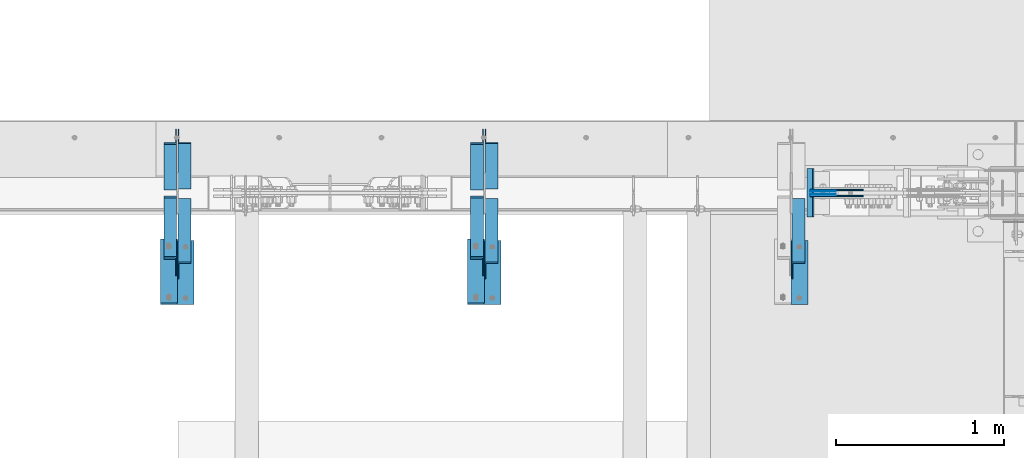
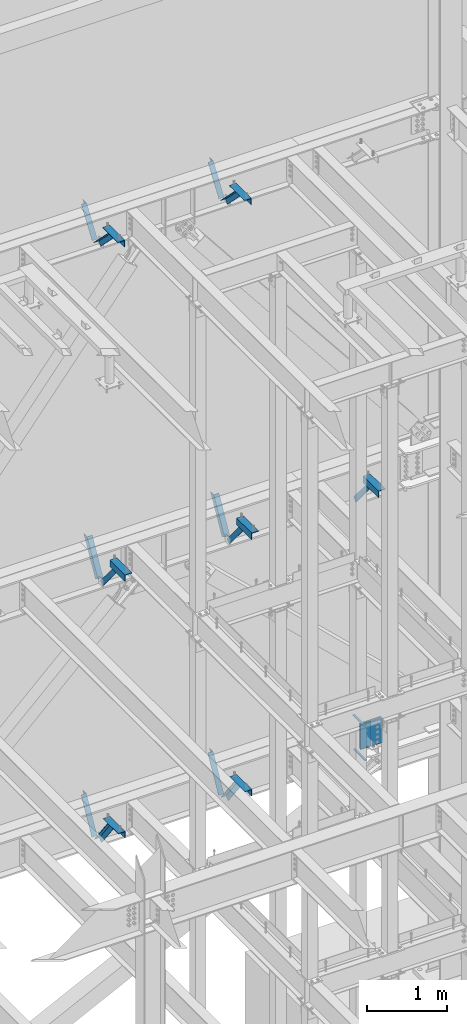
# One storey, part 925 of 1179: 13 beams, 13 members, 23 elements without a shape of their own.
"""IFC2X3 building model written with IfcOpenShell, lengths in millimetres."""

from ifc_helpers import new_model, si_unit, frame, origin_with_axes, place, context, subcontext, project, spatial, faceted_brep, material, type_object, element, aggregate, save


model = new_model("IFC2X3")

# Units and contexts
model_context = context("Model", 3, precision=1e-05, world=origin_with_axes())
body_context = subcontext(model_context, "Body", "Model", "MODEL_VIEW")
ifc_project = project(units=[si_unit("LENGTHUNIT", "METRE", prefix="MILLI"), si_unit("AREAUNIT", "SQUARE_METRE"), si_unit("VOLUMEUNIT", "CUBIC_METRE"), si_unit("MASSUNIT", "GRAM", prefix="KILO"), si_unit("TIMEUNIT", "SECOND"), si_unit("PLANEANGLEUNIT", "RADIAN"), si_unit("SOLIDANGLEUNIT", "STERADIAN"), si_unit("THERMODYNAMICTEMPERATUREUNIT", "DEGREE_CELSIUS"), si_unit("LUMINOUSINTENSITYUNIT", "LUMEN")], contexts=[model_context])

# Site, building, storey
site_placement = place(None, origin_with_axes())
site = spatial("IfcSite", under=ifc_project, at=site_placement, CompositionType="ELEMENT")
building_placement = place(site_placement, origin_with_axes())
building = spatial("IfcBuilding", under=site, at=building_placement, Name="Undefined", CompositionType="ELEMENT")
storey_placement = place(building_placement, origin_with_axes())
storey = spatial("IfcBuildingStorey", under=building, at=storey_placement, Name="Undefined", CompositionType="ELEMENT", Elevation=0.0)

# Assembly, member
assembly_1_placement = place(storey_placement, origin_with_axes())
assembly_1 = element("IfcElementAssembly", 1, at=assembly_1_placement, inside=storey, Name="ANGLE", AssemblyPlace="NOTDEFINED", PredefinedType="RIGID_FRAME")
ifc_material_1 = material(Name="STEEL/A36")
member_type = type_object("IfcMemberType", Name="L3X3X1/4", PredefinedType="NOTDEFINED")
member_1_placement = place(assembly_1_placement, frame((11503.025, 41137.0679040265, 7518.83524528677), z_axis=(0.0, -0.767806695844832, -0.640681572870519), x_axis=(0.0, -0.640681572870519, 0.767806695844831)))
member_1 = element("IfcMember", 2, at=member_1_placement, type_object=member_type, material=ifc_material_1, Name="ANGLE", ObjectType="L3X3X1/4", context=body_context, shape_type="Brep", body=[
    faceted_brep([(0.0, 38.0999999999985, -38.0999999999999), (0.0, 38.0999999999985, 38.0999999999999), (655.633410548446, 38.1000000000004, 38.0999999994965), (592.049781860664, 38.1000000000004, -38.1000000005733), (0.0, 31.75, 38.1000000000004), (655.633410548446, 31.75, 38.0999999994965), (0.0, 31.75, -31.75), (597.348417584646, 31.75, -31.7500000005675), (0.0, -38.0999999999985, -31.75), (597.348417584646, -38.1000000000004, -31.7500000005675), (0.0, -38.0999999999985, -38.0999999999999), (592.049781860664, -38.1000000000004, -38.1000000005733)], [[[0, 1, 2, 3]], [[1, 4, 5, 2]], [[4, 6, 7, 5]], [[6, 8, 9, 7]], [[8, 10, 11, 9]], [[10, 0, 3, 11]], [[5, 7, 9, 11, 3, 2]], [[10, 8, 6, 4, 1, 0]]]),
])
aggregate(assembly_1, [member_1])

assembly_2_placement = place(storey_placement, origin_with_axes())
assembly_2 = element("IfcElementAssembly", 3, at=assembly_2_placement, inside=storey, Name="ANGLE", AssemblyPlace="NOTDEFINED", PredefinedType="RIGID_FRAME")
member_2_placement = place(assembly_2_placement, frame((15160.625, 41137.0679040265, 7518.83524528677), z_axis=(0.0, -0.767806695844832, -0.640681572870519), x_axis=(0.0, -0.640681572870519, 0.767806695844831)))
member_2 = element("IfcMember", 4, at=member_2_placement, type_object=member_type, material=ifc_material_1, Name="ANGLE", ObjectType="L3X3X1/4", context=body_context, shape_type="Brep", body=[
    faceted_brep([(0.0, 38.0999999999985, -38.0999999999999), (0.0, 38.0999999999985, 38.0999999999999), (655.633410548446, 38.1000000000004, 38.0999999994965), (592.049781860664, 38.1000000000004, -38.1000000005733), (0.0, 31.75, 38.1000000000004), (655.633410548446, 31.75, 38.0999999994965), (0.0, 31.75, -31.75), (597.348417584646, 31.75, -31.7500000005675), (0.0, -38.0999999999985, -31.75), (597.348417584646, -38.1000000000004, -31.7500000005675), (0.0, -38.0999999999985, -38.0999999999999), (592.049781860664, -38.1000000000004, -38.1000000005733)], [[[0, 1, 2, 3]], [[1, 4, 5, 2]], [[4, 6, 7, 5]], [[6, 8, 9, 7]], [[8, 10, 11, 9]], [[10, 0, 3, 11]], [[5, 7, 9, 11, 3, 2]], [[10, 8, 6, 4, 1, 0]]]),
])
aggregate(assembly_2, [member_2])

assembly_3_placement = place(storey_placement, origin_with_axes())
assembly_3 = element("IfcElementAssembly", 5, at=assembly_3_placement, inside=storey, Name="ANGLE", AssemblyPlace="NOTDEFINED", PredefinedType="RIGID_FRAME")
member_3_placement = place(assembly_3_placement, frame((13331.825, 41137.0679040265, 7518.83524528677), z_axis=(0.0, -0.767806695844832, -0.640681572870519), x_axis=(0.0, -0.640681572870519, 0.767806695844831)))
member_3 = element("IfcMember", 6, at=member_3_placement, type_object=member_type, material=ifc_material_1, Name="ANGLE", ObjectType="L3X3X1/4", context=body_context, shape_type="Brep", body=[
    faceted_brep([(0.0, 38.0999999999985, -38.0999999999999), (0.0, 38.0999999999985, 38.0999999999999), (655.633410548446, 38.1000000000004, 38.0999999994965), (592.049781860664, 38.1000000000004, -38.1000000005733), (0.0, 31.75, 38.1000000000004), (655.633410548446, 31.75, 38.0999999994965), (0.0, 31.75, -31.75), (597.348417584646, 31.75, -31.7500000005675), (0.0, -38.0999999999985, -31.75), (597.348417584646, -38.1000000000004, -31.7500000005675), (0.0, -38.0999999999985, -38.0999999999999), (592.049781860664, -38.1000000000004, -38.1000000005733)], [[[0, 1, 2, 3]], [[1, 4, 5, 2]], [[4, 6, 7, 5]], [[6, 8, 9, 7]], [[8, 10, 11, 9]], [[10, 0, 3, 11]], [[5, 7, 9, 11, 3, 2]], [[10, 8, 6, 4, 1, 0]]]),
])
aggregate(assembly_3, [member_3])

assembly_4_placement = place(storey_placement, origin_with_axes())
assembly_4 = element("IfcElementAssembly", 7, at=assembly_4_placement, inside=storey, Name="ANGLE", AssemblyPlace="NOTDEFINED", PredefinedType="RIGID_FRAME")
member_4_placement = place(assembly_4_placement, frame((13331.825, 41656.0, 8227.31342088179), z_axis=(0.0, 0.872675718014636, -0.488300206008189), x_axis=(0.0, -0.48830020600819, -0.872675718014636)))
member_4 = element("IfcMember", 8, at=member_4_placement, type_object=member_type, material=ifc_material_1, Name="ANGLE", ObjectType="L3X3X1/4", context=body_context, shape_type="Brep", body=[
    faceted_brep([(266.09845322503, 38.1000000000004, -38.1000000001477), (223.461222774196, 38.1000000000004, 38.0999999997293), (818.212094408347, 38.1000000000004, 38.0999999992346), (818.21209440822, 38.1000000000004, -38.100000000617), (223.461222774196, 31.75, 38.0999999997293), (818.212094408347, 31.75, 38.0999999992346), (262.545350687458, 31.75, -31.7500000001601), (818.212094408227, 31.75, -31.7500000006257), (262.545350687458, -38.1000000000004, -31.7500000001601), (818.212094408227, -38.1000000000004, -31.7500000006257), (266.09845322503, -38.1000000000004, -38.1000000001477), (818.21209440822, -38.1000000000004, -38.100000000617)], [[[0, 1, 2, 3]], [[1, 4, 5, 2]], [[4, 6, 7, 5]], [[6, 8, 9, 7]], [[8, 10, 11, 9]], [[10, 0, 3, 11]], [[5, 7, 9, 11, 3, 2]], [[10, 8, 6, 4, 1, 0]]]),
])
aggregate(assembly_4, [member_4])

assembly_5_placement = place(storey_placement, origin_with_axes())
assembly_5 = element("IfcElementAssembly", 9, at=assembly_5_placement, inside=storey, Name="ANGLE", AssemblyPlace="NOTDEFINED", PredefinedType="RIGID_FRAME")
member_5_placement = place(assembly_5_placement, frame((11503.025, 41656.0, 8227.31342088179), z_axis=(0.0, 0.872675718014636, -0.488300206008189), x_axis=(0.0, -0.48830020600819, -0.872675718014636)))
member_5 = element("IfcMember", 10, at=member_5_placement, type_object=member_type, material=ifc_material_1, Name="ANGLE", ObjectType="L3X3X1/4", context=body_context, shape_type="Brep", body=[
    faceted_brep([(266.09845322503, 38.1000000000004, -38.1000000001477), (223.461222774196, 38.1000000000004, 38.0999999997293), (818.212094408347, 38.1000000000004, 38.0999999992346), (818.21209440822, 38.1000000000004, -38.100000000617), (223.461222774196, 31.75, 38.0999999997293), (818.212094408347, 31.75, 38.0999999992346), (262.545350687458, 31.75, -31.7500000001601), (818.212094408227, 31.75, -31.7500000006257), (262.545350687458, -38.1000000000004, -31.7500000001601), (818.212094408227, -38.1000000000004, -31.7500000006257), (266.09845322503, -38.1000000000004, -38.1000000001477), (818.21209440822, -38.1000000000004, -38.100000000617)], [[[0, 1, 2, 3]], [[1, 4, 5, 2]], [[4, 6, 7, 5]], [[6, 8, 9, 7]], [[8, 10, 11, 9]], [[10, 0, 3, 11]], [[5, 7, 9, 11, 3, 2]], [[10, 8, 6, 4, 1, 0]]]),
])
aggregate(assembly_5, [member_5])

assembly_6_placement = place(storey_placement, origin_with_axes())
assembly_6 = element("IfcElementAssembly", 11, at=assembly_6_placement, inside=storey, Name="ANGLE", AssemblyPlace="NOTDEFINED", PredefinedType="RIGID_FRAME")
member_6_placement = place(assembly_6_placement, frame((13246.10025, 41256.8364339201, 3601.33927004389), z_axis=(0.0, 0.873306509536275, -0.487171161299155), x_axis=(0.0, 0.487171161299156, 0.873306509536275)))
member_6 = element("IfcMember", 12, at=member_6_placement, type_object=member_type, material=ifc_material_1, Name="ANGLE", ObjectType="L3X3X1/4", context=body_context, shape_type="Brep", body=[
    faceted_brep([(0.0, 38.0999999999985, -38.0999999999999), (0.0, 38.0999999999985, 38.0999999999999), (594.661720177039, 38.1000000000004, 38.1000000011991), (552.153801037723, 38.1000000000004, -38.0999999989144), (0.0, 31.75, 38.1000000000004), (594.661720177039, 31.75, 38.1000000011991), (0.0, 31.75, -31.75), (555.696127632669, 31.75, -31.7499999988941), (0.0, -38.0999999999985, -31.75), (555.696127632669, -38.1000000000004, -31.7499999988941), (0.0, -38.0999999999985, -38.0999999999999), (552.153801037723, -38.1000000000004, -38.0999999989144)], [[[0, 1, 2, 3]], [[1, 4, 5, 2]], [[4, 6, 7, 5]], [[6, 8, 9, 7]], [[8, 10, 11, 9]], [[10, 0, 3, 11]], [[5, 7, 9, 11, 3, 2]], [[10, 8, 6, 4, 1, 0]]]),
])
aggregate(assembly_6, [member_6])

assembly_7_placement = place(storey_placement, origin_with_axes())
assembly_7 = element("IfcElementAssembly", 13, at=assembly_7_placement, inside=storey, Name="ANGLE", AssemblyPlace="NOTDEFINED", PredefinedType="RIGID_FRAME")
member_7_placement = place(assembly_7_placement, frame((13246.10025, 40722.5021746856, 4156.39103856133), z_axis=(0.0, -0.797785167426298, -0.602941810322185), x_axis=(0.0, 0.602941810322187, -0.797785167426297)))
member_7 = element("IfcMember", 14, at=member_7_placement, type_object=member_type, material=ifc_material_1, Name="ANGLE", ObjectType="L3X3X1/4", context=body_context, shape_type="Brep", body=[
    faceted_brep([(110.776215380578, 38.1000000000004, -38.1000000000058), (53.1865686658894, 38.1000000000004, 38.1000000001659), (690.351875241478, 38.1000000000004, 38.1000000007261), (690.351875241598, 38.1000000000004, -38.0999999994892), (53.1865686658894, 31.75, 38.1000000001659), (690.351875241478, 31.75, 38.1000000007261), (105.977078154352, 31.75, -31.7499999999927), (690.351875241595, 31.75, -31.7499999994689), (105.977078154352, -38.1000000000004, -31.7499999999927), (690.351875241595, -38.1000000000004, -31.7499999994689), (110.776215380578, -38.1000000000004, -38.1000000000058), (690.351875241598, -38.1000000000004, -38.0999999994892)], [[[0, 1, 2, 3]], [[1, 4, 5, 2]], [[4, 6, 7, 5]], [[6, 8, 9, 7]], [[8, 10, 11, 9]], [[10, 0, 3, 11]], [[5, 7, 9, 11, 3, 2]], [[10, 8, 6, 4, 1, 0]]]),
])
aggregate(assembly_7, [member_7])

assembly_8_placement = place(storey_placement, origin_with_axes())
assembly_8 = element("IfcElementAssembly", 15, at=assembly_8_placement, inside=storey, Name="ANGLE", AssemblyPlace="NOTDEFINED", PredefinedType="RIGID_FRAME")
member_8_placement = place(assembly_8_placement, frame((11417.30025, 40722.5021746856, 4156.39103856133), z_axis=(0.0, -0.797785167426298, -0.602941810322185), x_axis=(0.0, 0.602941810322187, -0.797785167426297)))
member_8 = element("IfcMember", 16, at=member_8_placement, type_object=member_type, material=ifc_material_1, Name="ANGLE", ObjectType="L3X3X1/4", context=body_context, shape_type="Brep", body=[
    faceted_brep([(110.776215380578, 38.1000000000004, -38.1000000000058), (53.1865686658894, 38.1000000000004, 38.1000000001659), (690.351875241478, 38.1000000000004, 38.1000000007261), (690.351875241598, 38.1000000000004, -38.0999999994892), (53.1865686658894, 31.75, 38.1000000001659), (690.351875241478, 31.75, 38.1000000007261), (105.977078154352, 31.75, -31.7499999999927), (690.351875241595, 31.75, -31.7499999994689), (105.977078154352, -38.1000000000004, -31.7499999999927), (690.351875241595, -38.1000000000004, -31.7499999994689), (110.776215380578, -38.1000000000004, -38.1000000000058), (690.351875241598, -38.1000000000004, -38.0999999994892)], [[[0, 1, 2, 3]], [[1, 4, 5, 2]], [[4, 6, 7, 5]], [[6, 8, 9, 7]], [[8, 10, 11, 9]], [[10, 0, 3, 11]], [[5, 7, 9, 11, 3, 2]], [[10, 8, 6, 4, 1, 0]]]),
])
aggregate(assembly_8, [member_8])

assembly_9_placement = place(storey_placement, origin_with_axes())
assembly_9 = element("IfcElementAssembly", 17, at=assembly_9_placement, inside=storey, Name="ANGLE", AssemblyPlace="NOTDEFINED", PredefinedType="RIGID_FRAME")
member_9_placement = place(assembly_9_placement, frame((11417.30025, 41256.8364339201, 3601.33927004389), z_axis=(0.0, 0.873306509536275, -0.487171161299155), x_axis=(0.0, 0.487171161299156, 0.873306509536275)))
member_9 = element("IfcMember", 18, at=member_9_placement, type_object=member_type, material=ifc_material_1, Name="ANGLE", ObjectType="L3X3X1/4", context=body_context, shape_type="Brep", body=[
    faceted_brep([(0.0, 38.0999999999985, -38.0999999999999), (0.0, 38.0999999999985, 38.0999999999999), (594.661720177039, 38.1000000000004, 38.1000000011991), (552.153801037723, 38.1000000000004, -38.0999999989144), (0.0, 31.75, 38.1000000000004), (594.661720177039, 31.75, 38.1000000011991), (0.0, 31.75, -31.75), (555.696127632669, 31.75, -31.7499999988941), (0.0, -38.0999999999985, -31.75), (555.696127632669, -38.1000000000004, -31.7499999988941), (0.0, -38.0999999999985, -38.0999999999999), (552.153801037723, -38.1000000000004, -38.0999999989144)], [[[0, 1, 2, 3]], [[1, 4, 5, 2]], [[4, 6, 7, 5]], [[6, 8, 9, 7]], [[8, 10, 11, 9]], [[10, 0, 3, 11]], [[5, 7, 9, 11, 3, 2]], [[10, 8, 6, 4, 1, 0]]]),
])
aggregate(assembly_9, [member_9])

assembly_10_placement = place(storey_placement, origin_with_axes())
assembly_10 = element("IfcElementAssembly", 19, at=assembly_10_placement, inside=storey, Name="ANGLE", AssemblyPlace="NOTDEFINED", PredefinedType="RIGID_FRAME")
member_10_placement = place(assembly_10_placement, frame((13246.1, 40704.7386537875, 13150.1502196524), z_axis=(0.0, -0.706388288025418, -0.707824545025474), x_axis=(0.0, 0.707824545025473, -0.706388288025419)))
member_10 = element("IfcMember", 20, at=member_10_placement, type_object=member_type, material=ifc_material_1, Name="ANGLE", ObjectType="L3X3X1/4", context=body_context, shape_type="Brep", body=[
    faceted_brep([(634.184990526992, 31.75, 38.0999999999767), (634.184990526996, 31.75, -31.7499999999636), (634.184990526996, -38.0999999999985, -31.7499999999636), (634.184990526996, -38.0999999999985, -38.0999999999549), (634.184990526996, 38.0999999999985, -38.0999999999549), (634.184990526992, 38.0999999999985, 38.0999999999767), (113.596638248473, -38.0999999999985, -38.0999999999549), (113.596638248473, 38.0999999999985, -38.0999999999549), (37.2417053522113, 38.0999999999985, 38.0999999999694), (37.2417053522113, 31.75, 38.0999999999694), (107.233727173789, 31.75, -31.7499999999709), (107.233727173789, -38.0999999999985, -31.7499999999709)], [[[0, 1, 2, 3, 4, 5]], [[4, 3, 6, 7]], [[5, 4, 7, 8]], [[0, 5, 8, 9]], [[1, 0, 9, 10]], [[2, 1, 10, 11]], [[3, 2, 11, 6]], [[10, 9, 8, 7, 6, 11]]]),
])
aggregate(assembly_10, [member_10])

assembly_11_placement = place(storey_placement, origin_with_axes())
assembly_11 = element("IfcElementAssembly", 21, at=assembly_11_placement, inside=storey, Name="ANGLE", AssemblyPlace="NOTDEFINED", PredefinedType="RIGID_FRAME")
member_11_placement = place(assembly_11_placement, frame((13246.1, 41248.3636551321, 12707.4244380128), z_axis=(0.0, 0.821716663099518, -0.569896241069015), x_axis=(0.0, 0.569896241069016, 0.821716663099518)))
member_11 = element("IfcMember", 22, at=member_11_placement, type_object=member_type, material=ifc_material_1, Name="ANGLE", ObjectType="L3X3X1/4", context=body_context, shape_type="Brep", body=[
    faceted_brep([(0.0, -38.0999999999985, -38.0999999999999), (0.0, -38.0999999999985, -31.75), (0.0, 31.75, -31.75), (0.0, 31.75, 38.1000000000004), (0.0, 38.0999999999985, 38.0999999999999), (0.0, 38.0999999999985, -38.0999999999999), (527.418547333735, 31.75, 38.0999999993364), (527.418547333735, 38.1000000000004, 38.0999999993364), (474.570533511644, 38.1000000000004, -38.1000000006607), (474.570533511644, -38.1000000000004, -38.1000000006607), (478.974534663488, -38.1000000000004, -31.7500000006621), (478.974534663488, 31.75, -31.7500000006621)], [[[0, 1, 2, 3, 4, 5]], [[4, 3, 6, 7]], [[5, 4, 7, 8]], [[0, 5, 8, 9]], [[1, 0, 9, 10]], [[2, 1, 10, 11]], [[3, 2, 11, 6]], [[10, 9, 8, 7, 6, 11]]]),
])
aggregate(assembly_11, [member_11])

assembly_12_placement = place(storey_placement, origin_with_axes())
assembly_12 = element("IfcElementAssembly", 23, at=assembly_12_placement, inside=storey, Name="ANGLE", AssemblyPlace="NOTDEFINED", PredefinedType="RIGID_FRAME")
member_12_placement = place(assembly_12_placement, frame((11417.3, 40704.7386537875, 13150.1502196524), z_axis=(0.0, -0.706388288025418, -0.707824545025474), x_axis=(0.0, 0.707824545025473, -0.706388288025419)))
member_12 = element("IfcMember", 24, at=member_12_placement, type_object=member_type, material=ifc_material_1, Name="ANGLE", ObjectType="L3X3X1/4", context=body_context, shape_type="Brep", body=[
    faceted_brep([(634.184990526992, 31.75, 38.0999999999767), (634.184990526996, 31.75, -31.7499999999636), (634.184990526996, -38.0999999999985, -31.7499999999636), (634.184990526996, -38.0999999999985, -38.0999999999549), (634.184990526996, 38.0999999999985, -38.0999999999549), (634.184990526992, 38.0999999999985, 38.0999999999767), (113.596638248473, -38.0999999999985, -38.0999999999549), (113.596638248473, 38.0999999999985, -38.0999999999549), (37.2417053522113, 38.0999999999985, 38.0999999999694), (37.2417053522113, 31.75, 38.0999999999694), (107.233727173789, 31.75, -31.7499999999709), (107.233727173789, -38.0999999999985, -31.7499999999709)], [[[0, 1, 2, 3, 4, 5]], [[4, 3, 6, 7]], [[5, 4, 7, 8]], [[0, 5, 8, 9]], [[1, 0, 9, 10]], [[2, 1, 10, 11]], [[3, 2, 11, 6]], [[10, 9, 8, 7, 6, 11]]]),
])
aggregate(assembly_12, [member_12])

assembly_13_placement = place(storey_placement, origin_with_axes())
assembly_13 = element("IfcElementAssembly", 25, at=assembly_13_placement, inside=storey, Name="ANGLE", AssemblyPlace="NOTDEFINED", PredefinedType="RIGID_FRAME")
member_13_placement = place(assembly_13_placement, frame((11417.3, 41248.3636551321, 12707.4244380128), z_axis=(0.0, 0.821716663099518, -0.569896241069015), x_axis=(0.0, 0.569896241069016, 0.821716663099518)))
member_13 = element("IfcMember", 26, at=member_13_placement, type_object=member_type, material=ifc_material_1, Name="ANGLE", ObjectType="L3X3X1/4", context=body_context, shape_type="Brep", body=[
    faceted_brep([(0.0, -38.0999999999985, -38.0999999999999), (0.0, -38.0999999999985, -31.75), (0.0, 31.75, -31.75), (0.0, 31.75, 38.1000000000004), (0.0, 38.0999999999985, 38.0999999999999), (0.0, 38.0999999999985, -38.0999999999999), (527.418547333735, 31.75, 38.0999999993364), (527.418547333735, 38.1000000000004, 38.0999999993364), (474.570533511644, 38.1000000000004, -38.1000000006607), (474.570533511644, -38.1000000000004, -38.1000000006607), (478.974534663488, -38.1000000000004, -31.7500000006621), (478.974534663488, 31.75, -31.7500000006621)], [[[0, 1, 2, 3, 4, 5]], [[4, 3, 6, 7]], [[5, 4, 7, 8]], [[0, 5, 8, 9]], [[1, 0, 9, 10]], [[2, 1, 10, 11]], [[3, 2, 11, 6]], [[10, 9, 8, 7, 6, 11]]]),
])
aggregate(assembly_13, [member_13])

# Assembly, beams
assembly_14_placement = place(storey_placement, origin_with_axes())
assembly_14 = element("IfcElementAssembly", 27, at=assembly_14_placement, inside=storey, Name="BEAM", AssemblyPlace="NOTDEFINED", PredefinedType="RIGID_FRAME")
ifc_material_2 = material(Name="STEEL/A572-GR.50")
beam_type_1 = type_object("IfcBeamType", PredefinedType="NOTDEFINED")
beam_1_placement = place(assembly_14_placement, frame((15253.9988154804, 41198.8000366209, 3548.0625), z_axis=(0.0, -1.0, 0.0), x_axis=(-1.0, 0.0, 0.0)))
beam_1 = element("IfcBeam", 28, at=beam_1_placement, type_object=beam_type_1, material=ifc_material_2, Name="PLATE", context=body_context, shape_type="Brep", body=[
    faceted_brep([(0.0, 4.76249999999982, -144.462500000001), (0.0, 4.76249999999982, 144.462500000001), (31.7500000000036, 4.76249999999982, 144.462500000001), (31.7500000000036, 4.76249999999982, -144.462500000001), (0.0, -4.76249999999982, 144.462500000001), (31.7500000000036, -4.76249999999982, 144.462500000001), (0.0, -4.76249999999982, -144.462500000001), (31.7500000000036, -4.76249999999982, -144.462500000001)], [[[0, 1, 2, 3]], [[1, 4, 5, 2]], [[4, 6, 7, 5]], [[6, 0, 3, 7]], [[5, 7, 3, 2]], [[6, 4, 1, 0]]]),
])
beam_2_placement = place(assembly_14_placement, frame((15242.8668003494, 41198.8000366209, 4073.128), z_axis=(0.0, -1.0, 0.0), x_axis=(-1.0, 0.0, 0.0)))
beam_2 = element("IfcBeam", 29, at=beam_2_placement, type_object=beam_type_1, material=ifc_material_2, Name="PLATE", context=body_context, shape_type="Brep", body=[
    faceted_brep([(0.0, 4.76249999999982, -144.462500000001), (0.0, 4.76249999999982, 144.462500000001), (31.7500000000036, 4.76249999999982, 144.462500000001), (31.7500000000036, 4.76249999999982, -144.462500000001), (0.0, -4.76249999999982, 144.462500000001), (31.7500000000036, -4.76249999999982, 144.462500000001), (0.0, -4.76249999999982, -144.462500000001), (31.7500000000036, -4.76249999999982, -144.462500000001)], [[[0, 1, 2, 3]], [[1, 4, 5, 2]], [[4, 6, 7, 5]], [[6, 0, 3, 7]], [[5, 7, 3, 2]], [[6, 4, 1, 0]]]),
])
beam_type_2 = type_object("IfcBeamType", PredefinedType="NOTDEFINED")
beam_3_placement = place(assembly_14_placement, frame((15382.5668001509, 41189.27475, 3827.4625), z_axis=(0.0, 0.0, 1.0), x_axis=(-1.0, 0.0, 0.0)))
beam_3 = element("IfcBeam", 30, at=beam_3_placement, type_object=beam_type_2, material=ifc_material_2, Name="PLATE", context=body_context, shape_type="Brep", body=[
    faceted_brep([(0.0, 2.38150000000314, -190.5), (0.0, 2.38150000000314, 190.5), (152.399999999998, 2.38150000000314, 190.5), (152.399999999998, 2.38150000000314, -190.5), (0.0, -2.38150000000314, 190.5), (152.399999999998, -2.38150000000314, 190.5), (0.0, -2.38150000000314, -190.5), (152.399999999998, -2.38150000000314, -190.5)], [[[0, 1, 2, 3]], [[1, 4, 5, 2]], [[4, 6, 7, 5]], [[6, 0, 3, 7]], [[5, 7, 3, 2]], [[6, 4, 1, 0]]]),
])
beam_4_placement = place(assembly_14_placement, frame((15382.5668001509, 41208.32525, 3827.4625), z_axis=(0.0, 0.0, 1.0), x_axis=(-1.0, 0.0, 0.0)))
beam_4 = element("IfcBeam", 31, at=beam_4_placement, type_object=beam_type_2, material=ifc_material_2, Name="PLATE", context=body_context, shape_type="Brep", body=[
    faceted_brep([(0.0, 2.38150000000314, -190.5), (0.0, 2.38150000000314, 190.5), (152.399999999998, 2.38150000000314, 190.5), (152.399999999998, 2.38150000000314, -190.5), (0.0, -2.38150000000314, 190.5), (152.399999999998, -2.38150000000314, 190.5), (0.0, -2.38150000000314, -190.5), (152.399999999998, -2.38150000000314, -190.5)], [[[0, 1, 2, 3]], [[1, 4, 5, 2]], [[4, 6, 7, 5]], [[6, 0, 3, 7]], [[5, 7, 3, 2]], [[6, 4, 1, 0]]]),
])
aggregate(assembly_14, [beam_1, beam_2, beam_3, beam_4])

# Assembly, beam
assembly_15_placement = place(storey_placement, origin_with_axes())
assembly_15 = element("IfcElementAssembly", 32, at=assembly_15_placement, inside=storey, Name="ANGLE", AssemblyPlace="NOTDEFINED", PredefinedType="RIGID_FRAME")
beam_type_3 = type_object("IfcBeamType", Name="L4X4X1/4", PredefinedType="NOTDEFINED")
beam_5_placement = place(assembly_15_placement, frame((15166.975, 40533.6375, 7962.9), z_axis=(1.0, 0.0, 0.0), x_axis=(0.0, 1.0, 0.0)))
beam_5 = element("IfcBeam", 33, at=beam_5_placement, type_object=beam_type_3, material=ifc_material_1, Name="ANGLE", ObjectType="L4X4X1/4", context=body_context, shape_type="Brep", body=[
    faceted_brep([(1.90993887372315e-11, 50.8000000000002, -50.8000000000002), (1.90993887372315e-11, 50.8000000000002, 50.8000000000002), (381.0, 50.8000000000002, 50.7999999999993), (381.0, 50.8000000000002, -50.7999999999993), (0.0, 44.4500000000007, 50.8000000000002), (381.0, 44.4499999999998, 50.7999999999993), (0.0, 44.4500000000007, -44.4499999999998), (381.0, 44.4499999999998, -44.4500000000007), (0.0, -50.7999999999993, -44.4499999999998), (381.0, -50.8000000000002, -44.4500000000007), (-1.81898940354586e-11, -50.7999999999997, -50.8000000000002), (381.0, -50.8000000000002, -50.7999999999993)], [[[0, 1, 2, 3]], [[1, 4, 5, 2]], [[4, 6, 7, 5]], [[6, 8, 9, 7]], [[8, 10, 11, 9]], [[10, 0, 3, 11]], [[5, 7, 9, 11, 3, 2]], [[10, 8, 6, 4, 1, 0]]]),
])
aggregate(assembly_15, [beam_5])

assembly_16_placement = place(storey_placement, origin_with_axes())
assembly_16 = element("IfcElementAssembly", 34, at=assembly_16_placement, inside=storey, Name="ANGLE", AssemblyPlace="NOTDEFINED", PredefinedType="RIGID_FRAME")
beam_6_placement = place(assembly_16_placement, frame((13338.175, 40533.6375, 7962.9), z_axis=(1.0, 0.0, 0.0), x_axis=(0.0, 1.0, 0.0)))
beam_6 = element("IfcBeam", 35, at=beam_6_placement, type_object=beam_type_3, material=ifc_material_1, Name="ANGLE", ObjectType="L4X4X1/4", context=body_context, shape_type="Brep", body=[
    faceted_brep([(1.90993887372315e-11, 50.8000000000002, -50.8000000000002), (1.90993887372315e-11, 50.8000000000002, 50.8000000000002), (381.0, 50.8000000000002, 50.7999999999993), (381.0, 50.8000000000002, -50.7999999999993), (0.0, 44.4500000000007, 50.8000000000002), (381.0, 44.4499999999998, 50.7999999999993), (0.0, 44.4500000000007, -44.4499999999998), (381.0, 44.4499999999998, -44.4500000000007), (0.0, -50.7999999999993, -44.4499999999998), (381.0, -50.8000000000002, -44.4500000000007), (-1.81898940354586e-11, -50.7999999999997, -50.8000000000002), (381.0, -50.8000000000002, -50.7999999999993)], [[[0, 1, 2, 3]], [[1, 4, 5, 2]], [[4, 6, 7, 5]], [[6, 8, 9, 7]], [[8, 10, 11, 9]], [[10, 0, 3, 11]], [[5, 7, 9, 11, 3, 2]], [[10, 8, 6, 4, 1, 0]]]),
])
aggregate(assembly_16, [beam_6])

assembly_17_placement = place(storey_placement, origin_with_axes())
assembly_17 = element("IfcElementAssembly", 36, at=assembly_17_placement, inside=storey, Name="ANGLE", AssemblyPlace="NOTDEFINED", PredefinedType="RIGID_FRAME")
beam_7_placement = place(assembly_17_placement, frame((11509.375, 40533.6375, 7962.9), z_axis=(1.0, 0.0, 0.0), x_axis=(0.0, 1.0, 0.0)))
beam_7 = element("IfcBeam", 37, at=beam_7_placement, type_object=beam_type_3, material=ifc_material_1, Name="ANGLE", ObjectType="L4X4X1/4", context=body_context, shape_type="Brep", body=[
    faceted_brep([(1.90993887372315e-11, 50.8000000000002, -50.8000000000002), (1.90993887372315e-11, 50.8000000000002, 50.8000000000002), (381.0, 50.8000000000002, 50.7999999999993), (381.0, 50.8000000000002, -50.7999999999993), (0.0, 44.4500000000007, 50.8000000000002), (381.0, 44.4499999999998, 50.7999999999993), (0.0, 44.4500000000007, -44.4499999999998), (381.0, 44.4499999999998, -44.4500000000007), (0.0, -50.7999999999993, -44.4499999999998), (381.0, -50.8000000000002, -44.4500000000007), (-1.81898940354586e-11, -50.7999999999997, -50.8000000000002), (381.0, -50.8000000000002, -50.7999999999993)], [[[0, 1, 2, 3]], [[1, 4, 5, 2]], [[4, 6, 7, 5]], [[6, 8, 9, 7]], [[8, 10, 11, 9]], [[10, 0, 3, 11]], [[5, 7, 9, 11, 3, 2]], [[10, 8, 6, 4, 1, 0]]]),
])
aggregate(assembly_17, [beam_7])

assembly_18_placement = place(storey_placement, origin_with_axes())
assembly_18 = element("IfcElementAssembly", 38, at=assembly_18_placement, inside=storey, Name="ANGLE", AssemblyPlace="NOTDEFINED", PredefinedType="RIGID_FRAME")
beam_8_placement = place(assembly_18_placement, frame((13239.7502499985, 40914.6373750007, 4051.30000000071), z_axis=(-1.0, 0.0, 0.0), x_axis=(0.0, -1.0, 0.0)))
beam_8 = element("IfcBeam", 39, at=beam_8_placement, type_object=beam_type_3, material=ifc_material_1, Name="ANGLE", ObjectType="L4X4X1/4", context=body_context, shape_type="Brep", body=[
    faceted_brep([(1.90993887372315e-11, 50.8000000000002, -50.8000000000002), (1.90993887372315e-11, 50.8000000000002, 50.8000000000002), (381.0, 50.8000000000002, 50.7999999999993), (381.0, 50.8000000000002, -50.7999999999993), (0.0, 44.4500000000007, 50.8000000000002), (381.0, 44.4499999999998, 50.7999999999993), (0.0, 44.4500000000007, -44.4499999999998), (381.0, 44.4499999999998, -44.4500000000007), (0.0, -50.7999999999993, -44.4499999999998), (381.0, -50.8000000000002, -44.4500000000007), (-1.81898940354586e-11, -50.7999999999997, -50.8000000000002), (381.0, -50.8000000000002, -50.7999999999993)], [[[0, 1, 2, 3]], [[1, 4, 5, 2]], [[4, 6, 7, 5]], [[6, 8, 9, 7]], [[8, 10, 11, 9]], [[10, 0, 3, 11]], [[5, 7, 9, 11, 3, 2]], [[10, 8, 6, 4, 1, 0]]]),
])
aggregate(assembly_18, [beam_8])

assembly_19_placement = place(storey_placement, origin_with_axes())
assembly_19 = element("IfcElementAssembly", 40, at=assembly_19_placement, inside=storey, Name="ANGLE", AssemblyPlace="NOTDEFINED", PredefinedType="RIGID_FRAME")
beam_9_placement = place(assembly_19_placement, frame((11410.9502499985, 40914.6373750007, 4051.30000000071), z_axis=(-1.0, 0.0, 0.0), x_axis=(0.0, -1.0, 0.0)))
beam_9 = element("IfcBeam", 41, at=beam_9_placement, type_object=beam_type_3, material=ifc_material_1, Name="ANGLE", ObjectType="L4X4X1/4", context=body_context, shape_type="Brep", body=[
    faceted_brep([(1.90993887372315e-11, 50.8000000000002, -50.8000000000002), (1.90993887372315e-11, 50.8000000000002, 50.8000000000002), (381.0, 50.8000000000002, 50.7999999999993), (381.0, 50.8000000000002, -50.7999999999993), (0.0, 44.4500000000007, 50.8000000000002), (381.0, 44.4499999999998, 50.7999999999993), (0.0, 44.4500000000007, -44.4499999999998), (381.0, 44.4499999999998, -44.4500000000007), (0.0, -50.7999999999993, -44.4499999999998), (381.0, -50.8000000000002, -44.4500000000007), (-1.81898940354586e-11, -50.7999999999997, -50.8000000000002), (381.0, -50.8000000000002, -50.7999999999993)], [[[0, 1, 2, 3]], [[1, 4, 5, 2]], [[4, 6, 7, 5]], [[6, 8, 9, 7]], [[8, 10, 11, 9]], [[10, 0, 3, 11]], [[5, 7, 9, 11, 3, 2]], [[10, 8, 6, 4, 1, 0]]]),
])
aggregate(assembly_19, [beam_9])

assembly_20_placement = place(storey_placement, origin_with_axes())
assembly_20 = element("IfcElementAssembly", 42, at=assembly_20_placement, inside=storey, Name="ANGLE", AssemblyPlace="NOTDEFINED", PredefinedType="RIGID_FRAME")
beam_10_placement = place(assembly_20_placement, frame((13239.749999998, 40924.1624999531, 13068.3), z_axis=(-1.0, 0.0, 0.0), x_axis=(0.0, -1.0, 0.0)))
beam_10 = element("IfcBeam", 43, at=beam_10_placement, type_object=beam_type_3, material=ifc_material_1, Name="ANGLE", ObjectType="L4X4X1/4", context=body_context, shape_type="Brep", body=[
    faceted_brep([(1.90993887372315e-11, 50.8000000000002, -50.8000000000002), (1.90993887372315e-11, 50.8000000000002, 50.8000000000002), (381.0, 50.8000000000002, 50.7999999999993), (381.0, 50.8000000000002, -50.7999999999993), (0.0, 44.4500000000007, 50.8000000000002), (381.0, 44.4499999999998, 50.7999999999993), (0.0, 44.4500000000007, -44.4499999999998), (381.0, 44.4499999999998, -44.4500000000007), (0.0, -50.7999999999993, -44.4499999999998), (381.0, -50.8000000000002, -44.4500000000007), (-1.81898940354586e-11, -50.7999999999997, -50.8000000000002), (381.0, -50.8000000000002, -50.7999999999993)], [[[0, 1, 2, 3]], [[1, 4, 5, 2]], [[4, 6, 7, 5]], [[6, 8, 9, 7]], [[8, 10, 11, 9]], [[10, 0, 3, 11]], [[5, 7, 9, 11, 3, 2]], [[10, 8, 6, 4, 1, 0]]]),
])
aggregate(assembly_20, [beam_10])

assembly_21_placement = place(storey_placement, origin_with_axes())
assembly_21 = element("IfcElementAssembly", 44, at=assembly_21_placement, inside=storey, Name="ANGLE", AssemblyPlace="NOTDEFINED", PredefinedType="RIGID_FRAME")
beam_11_placement = place(assembly_21_placement, frame((11410.949999998, 40924.1624999531, 13068.3), z_axis=(-1.0, 0.0, 0.0), x_axis=(0.0, -1.0, 0.0)))
beam_11 = element("IfcBeam", 45, at=beam_11_placement, type_object=beam_type_3, material=ifc_material_1, Name="ANGLE", ObjectType="L4X4X1/4", context=body_context, shape_type="Brep", body=[
    faceted_brep([(1.90993887372315e-11, 50.8000000000002, -50.8000000000002), (1.90993887372315e-11, 50.8000000000002, 50.8000000000002), (381.0, 50.8000000000002, 50.7999999999993), (381.0, 50.8000000000002, -50.7999999999993), (0.0, 44.4500000000007, 50.8000000000002), (381.0, 44.4499999999998, 50.7999999999993), (0.0, 44.4500000000007, -44.4499999999998), (381.0, 44.4499999999998, -44.4500000000007), (0.0, -50.7999999999993, -44.4499999999998), (381.0, -50.8000000000002, -44.4500000000007), (-1.81898940354586e-11, -50.7999999999997, -50.8000000000002), (381.0, -50.8000000000002, -50.7999999999993)], [[[0, 1, 2, 3]], [[1, 4, 5, 2]], [[4, 6, 7, 5]], [[6, 8, 9, 7]], [[8, 10, 11, 9]], [[10, 0, 3, 11]], [[5, 7, 9, 11, 3, 2]], [[10, 8, 6, 4, 1, 0]]]),
])
aggregate(assembly_21, [beam_11])

assembly_22_placement = place(storey_placement, origin_with_axes())
assembly_22 = element("IfcElementAssembly", 46, at=assembly_22_placement, inside=storey, Name="PLATE", AssemblyPlace="NOTDEFINED", PredefinedType="RIGID_FRAME")
beam_type_4 = type_object("IfcBeamType", PredefinedType="NOTDEFINED")
beam_12_placement = place(assembly_22_placement, frame((15230.1668001509, 41181.3375, 3827.4625), z_axis=(0.0, 0.0, -1.0), x_axis=(1.0, 0.0, 0.0)))
beam_12 = element("IfcBeam", 47, at=beam_12_placement, type_object=beam_type_4, material=ifc_material_2, Name="PLATE", context=body_context, shape_type="Brep", body=[
    faceted_brep([(0.0, 4.76249999999709, -190.5), (0.0, 4.76249999999709, 190.5), (317.499999999995, 4.76250000000073, 190.500000000051), (317.500000000042, 4.76250000000073, -190.499999999973), (0.0, -4.76249999999709, 190.5), (317.499999999995, -4.76250000000073, 190.500000000051), (0.0, -4.76249999999709, -190.5), (317.500000000042, -4.76250000000073, -190.499999999973)], [[[0, 1, 2, 3]], [[1, 4, 5, 2]], [[4, 6, 7, 5]], [[6, 0, 3, 7]], [[5, 7, 3, 2]], [[6, 4, 1, 0]]]),
])
aggregate(assembly_22, [beam_12])

assembly_23_placement = place(storey_placement, origin_with_axes())
assembly_23 = element("IfcElementAssembly", 48, at=assembly_23_placement, inside=storey, Name="PLATE", AssemblyPlace="NOTDEFINED", PredefinedType="RIGID_FRAME")
beam_13_placement = place(assembly_23_placement, frame((15547.6668001509, 41216.2625, 3827.4625), z_axis=(0.0, 0.0, -1.0), x_axis=(-1.0, 0.0, 0.0)))
beam_13 = element("IfcBeam", 49, at=beam_13_placement, type_object=beam_type_4, material=ifc_material_2, Name="PLATE", context=body_context, shape_type="Brep", body=[
    faceted_brep([(0.0, 4.76249999999709, -190.5), (0.0, 4.76249999999709, 190.5), (317.499999999995, 4.76250000000073, 190.500000000051), (317.500000000042, 4.76250000000073, -190.499999999973), (0.0, -4.76249999999709, 190.5), (317.499999999995, -4.76250000000073, 190.500000000051), (0.0, -4.76249999999709, -190.5), (317.500000000042, -4.76250000000073, -190.499999999973)], [[[0, 1, 2, 3]], [[1, 4, 5, 2]], [[4, 6, 7, 5]], [[6, 0, 3, 7]], [[5, 7, 3, 2]], [[6, 4, 1, 0]]]),
])
aggregate(assembly_23, [beam_13])

save(model, "model.ifc")
